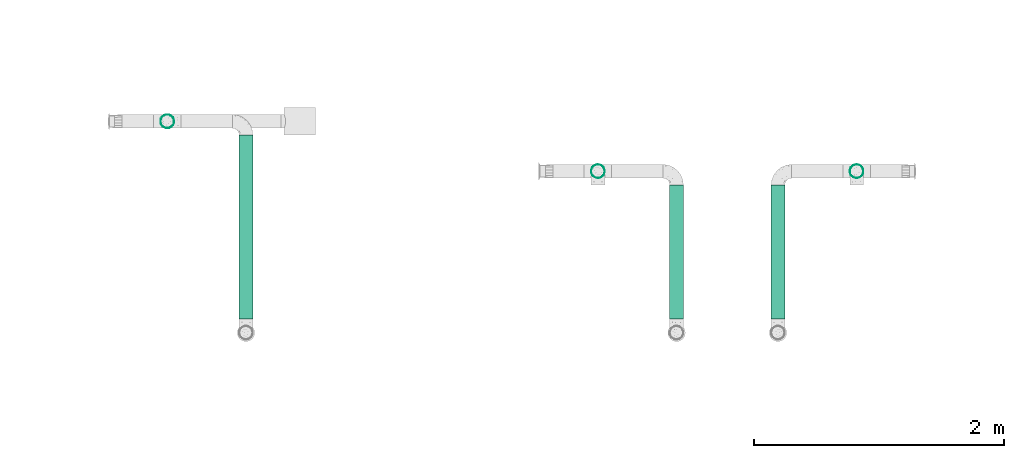
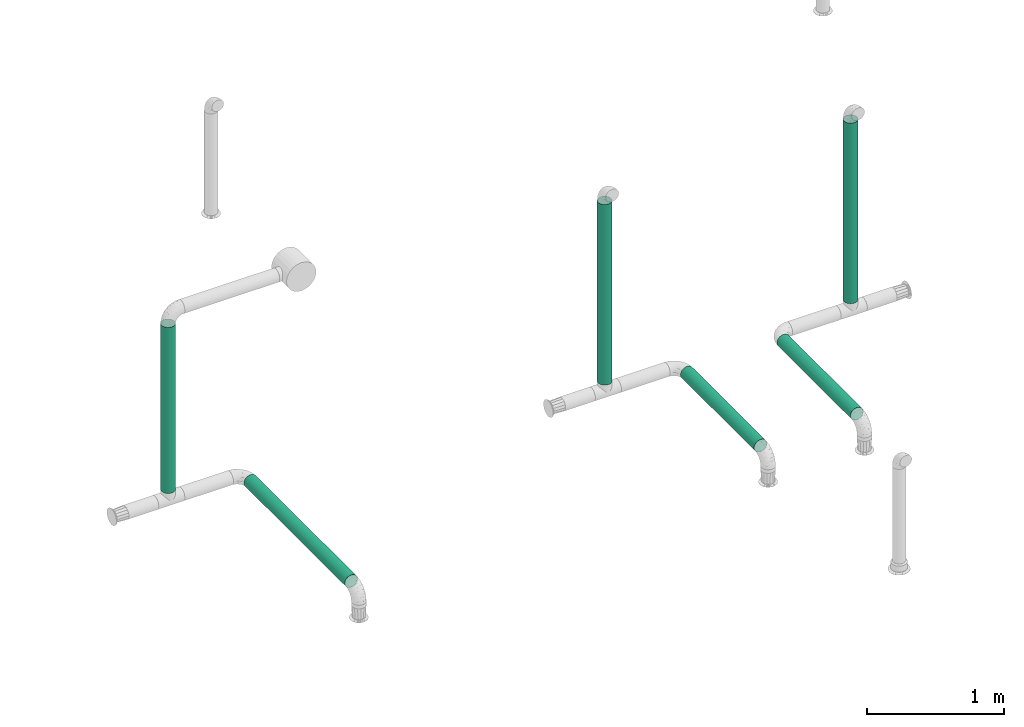
# One storey, part 2 of 103: 6 flow segments.
"""IFC2X3 building model written with IfcOpenShell, lengths in millimetres."""

import ifcopenshell
import ifcopenshell.guid

model = None  # the IFC model being written
_history = None  # IfcOwnerHistory: only IFC2X3 demands one
_inside = {}  # id of a spatial element -> (the spatial element, [elements in it])
_under = {}  # id of a project, library or spatial element -> (it, [spatial elements below it])
_declared = {}  # id of a project -> (the project, [libraries it declares])
_typed = {}  # id of a type object -> (the type object, [elements of that type])
_made_of = {}  # id of a material, layer set ... -> (it, [elements and type objects made of it])


def new_model(schema):
    """Start an empty IFC model of exactly this schema.

    Asked for "IFC4X3", IfcOpenShell would pick the latest addendum, in which some entities
    have other attributes; the version numbers below select the first issue.
    IFC2X3 requires an IfcOwnerHistory on every rooted entity: one is made here for all.
    """
    global model, _history
    if schema == "IFC4X3":
        model = ifcopenshell.file(schema_version=(4, 3, 0, 0))
    else:
        model = ifcopenshell.file(schema=schema)
    _inside.clear()
    _under.clear()
    _declared.clear()
    _typed.clear()
    _made_of.clear()
    _history = None
    if model.schema == "IFC2X3":
        org = make("IfcOrganization", Name="unknown")
        user = make(
            "IfcPersonAndOrganization",
            ThePerson=make("IfcPerson", FamilyName="unknown"),
            TheOrganization=org,
        )
        app = make(
            "IfcApplication",
            ApplicationDeveloper=org,
            Version="unknown",
            ApplicationFullName="unknown",
            ApplicationIdentifier="unknown",
        )
        _history = make(
            "IfcOwnerHistory",
            OwningUser=user,
            OwningApplication=app,
            ChangeAction="ADDED",
            CreationDate=0,
        )
    return model


def make(cls, **values):
    """One entity of the class cls with the attributes given. An attribute that is None is left unset."""
    return model.create_entity(
        cls, **{name: value for name, value in values.items() if value is not None}
    )


def entity(cls, *values):
    """Any entity or typed value of the class cls, its attributes in the order of the schema. None: left unset."""
    e = model.create_entity(cls)
    for i, value in enumerate(values):
        if value is not None:
            e[i] = value
    return e


def rooted(cls, **values):
    """An entity with a GlobalId (a new one), such as an element, a storey or a relation."""
    return make(cls, GlobalId=ifcopenshell.guid.new(), OwnerHistory=_history, **values)


def si_unit(unit_type, name, prefix=None):
    """IfcSIUnit, for example si_unit("LENGTHUNIT", "METRE", prefix="MILLI")."""
    return make("IfcSIUnit", UnitType=unit_type, Prefix=prefix, Name=name)


def converted_unit(unit_type, name, factor, base, dimensions=None, offset=None):
    """IfcConversionBasedUnit, such as the inch: factor (a typed value) times the base unit."""
    return make(
        "IfcConversionBasedUnit"
        if offset is None
        else "IfcConversionBasedUnitWithOffset",
        ConversionOffset=offset,
        Dimensions=None
        if dimensions is None
        else entity("IfcDimensionalExponents", *dimensions),
        UnitType=unit_type,
        Name=name,
        ConversionFactor=make(
            "IfcMeasureWithUnit", ValueComponent=factor, UnitComponent=base
        ),
    )


def derived_unit(unit_type, elements):
    """IfcDerivedUnit: a product of units, each with its exponent."""
    return make(
        "IfcDerivedUnit",
        Elements=[
            make("IfcDerivedUnitElement", Unit=unit, Exponent=power)
            for unit, power in elements
        ],
        UnitType=unit_type,
    )


def assignment(units):
    """IfcUnitAssignment: the units of a project."""
    return None if units is None else make("IfcUnitAssignment", Units=units)


def point(xyz):
    """IfcCartesianPoint."""
    return None if xyz is None else make("IfcCartesianPoint", Coordinates=xyz)


def direction(xyz):
    """IfcDirection."""
    return None if xyz is None else make("IfcDirection", DirectionRatios=xyz)


def frame(location, z_axis=None, x_axis=None):
    """IfcAxis2Placement3D, a coordinate frame: its origin and axes. An axis left out is left unset."""
    return make(
        "IfcAxis2Placement3D",
        Location=point(location),
        Axis=direction(z_axis),
        RefDirection=direction(x_axis),
    )


def frame_2d(location, x_axis=None):
    """IfcAxis2Placement2D, a coordinate frame in the plane: its origin and x axis."""
    return make(
        "IfcAxis2Placement2D", Location=point(location), RefDirection=direction(x_axis)
    )


def origin_with_axes():
    """The frame at (0, 0, 0) with the z axis (0, 0, 1) and the x axis (1, 0, 0) written out."""
    return frame((0.0, 0.0, 0.0), z_axis=(0.0, 0.0, 1.0), x_axis=(1.0, 0.0, 0.0))


def origin_2d_with_axis():
    """The frame at (0, 0) in the plane with the x axis (1, 0) written out."""
    return frame_2d((0.0, 0.0), x_axis=(1.0, 0.0))


def place(relative_to, where):
    """IfcLocalPlacement: puts the frame where relative to a parent placement (None: the world)."""
    return make(
        "IfcLocalPlacement", PlacementRelTo=relative_to, RelativePlacement=where
    )


def context(
    kind, dimensions, precision=None, world=None, true_north=None, identifier=None
):
    """IfcGeometricRepresentationContext, for example the 3D "Model" context."""
    return make(
        "IfcGeometricRepresentationContext",
        ContextIdentifier=identifier,
        ContextType=kind,
        CoordinateSpaceDimension=dimensions,
        Precision=precision,
        WorldCoordinateSystem=world,
        TrueNorth=true_north,
    )


def subcontext(parent, identifier, kind, view, scale=None):
    """IfcGeometricRepresentationSubContext, for example "Body" below "Model"."""
    return make(
        "IfcGeometricRepresentationSubContext",
        ContextIdentifier=identifier,
        ContextType=kind,
        ParentContext=parent,
        TargetScale=scale,
        TargetView=view,
    )


def project(units=None, contexts=None):
    """IfcProject with its units and contexts."""
    return rooted(
        "IfcProject",
        Name="project",
        RepresentationContexts=contexts,
        UnitsInContext=assignment(units),
    )


def spatial(cls, under=None, at=None, **own):
    """A site, building, storey or space (cls), placed at a placement, below another one or the project."""
    s = rooted(cls, ObjectPlacement=at, **own)
    if under is not None:
        _under.setdefault(under.id(), (under, []))[1].append(s)
    return s


def profile(cls, at=None, kind="AREA", **sizes):
    """A parametric profile (cls). Its sizes go by their IFC names, for example OverallWidth=200.0."""
    return make(cls, ProfileType=kind, Position=at, **sizes)


def hollow_circle(**sizes):
    """IfcCircleHollowProfileDef."""
    return profile("IfcCircleHollowProfileDef", **sizes)


def extrude(swept, where, along, depth):
    """IfcExtrudedAreaSolid: the profile swept, set in the frame where, extruded along a direction by depth."""
    return make(
        "IfcExtrudedAreaSolid",
        SweptArea=swept,
        Position=where,
        ExtrudedDirection=direction(along),
        Depth=depth,
    )


def shape(context_of_items, identifier, shape_type, items):
    """IfcShapeRepresentation: the items that make up one representation, for example the "Body"."""
    return make(
        "IfcShapeRepresentation",
        ContextOfItems=context_of_items,
        RepresentationIdentifier=identifier,
        RepresentationType=shape_type,
        Items=items,
    )


def source(mapping_origin, context_of_items, identifier, shape_type, items):
    """IfcRepresentationMap: a shape defined once, which mapped items show again and again."""
    return make(
        "IfcRepresentationMap",
        MappingOrigin=mapping_origin,
        MappedRepresentation=shape(context_of_items, identifier, shape_type, items),
    )


def transform(
    local_origin,
    x_axis=None,
    y_axis=None,
    z_axis=None,
    scale=None,
    scale2=None,
    scale3=None,
    uniform=True,
):
    """IfcCartesianTransformationOperator3D, or its non-uniform kind. x_axis, y_axis, z_axis: its Axis1, 2, 3."""
    if uniform:
        return make(
            "IfcCartesianTransformationOperator3D",
            Axis1=direction(x_axis),
            Axis2=direction(y_axis),
            LocalOrigin=point(local_origin),
            Scale=scale,
            Axis3=direction(z_axis),
        )
    return make(
        "IfcCartesianTransformationOperator3DnonUniform",
        Axis1=direction(x_axis),
        Axis2=direction(y_axis),
        LocalOrigin=point(local_origin),
        Scale=scale,
        Axis3=direction(z_axis),
        Scale2=scale2,
        Scale3=scale3,
    )


def mapped(mapping_source, mapping_target):
    """IfcMappedItem: shows the shape of a source again, moved by a transform."""
    return make(
        "IfcMappedItem", MappingSource=mapping_source, MappingTarget=mapping_target
    )


def material(Name=None, Category=None):
    """IfcMaterial."""
    return make("IfcMaterial", Name=Name, Category=Category)


def layer(
    of_material, thickness, ventilated=None, Name=None, Category=None, Priority=None
):
    """IfcMaterialLayer: one layer of a wall or slab, of a material (None: an air gap)."""
    return make(
        "IfcMaterialLayer",
        Material=of_material,
        LayerThickness=thickness,
        IsVentilated=ventilated,
        Name=Name,
        Category=Category,
        Priority=Priority,
    )


def layer_set(layers, Name=None):
    """IfcMaterialLayerSet."""
    return make("IfcMaterialLayerSet", MaterialLayers=layers, LayerSetName=Name)


def layer_usage(for_layer_set, set_direction, sense, offset, extent=None):
    """IfcMaterialLayerSetUsage: how a layer set lies in its element."""
    return make(
        "IfcMaterialLayerSetUsage",
        ForLayerSet=for_layer_set,
        LayerSetDirection=set_direction,
        DirectionSense=sense,
        OffsetFromReferenceLine=offset,
        ReferenceExtent=extent,
    )


def made_of(thing, what):
    """Note that an element or type object is made of a material, layer set ...; save() writes the relation."""
    if what is not None:
        _made_of.setdefault(what.id(), (what, []))[1].append(thing)
    return thing


def type_object(cls, material=None, **own):
    """A type object (cls), such as IfcWallType, which elements share."""
    return made_of(rooted(cls, **own), material)


def element(
    cls,
    number,
    at=None,
    inside=None,
    cuts=None,
    type_object=None,
    material=None,
    context=None,
    identifier="Body",
    shape_type=None,
    held_by="IfcProductDefinitionShape",
    body=None,
    shapes=None,
    **own,
):
    """One element of the class cls, such as IfcWall. Its Tag is "e" and its number.

    at: its placement. inside: the storey or other place that contains it. cuts: it is an
    opening in that element (IfcRelVoidsElement). A single representation is given by context,
    identifier, shape_type and body (its items); several are given by shapes. held_by: the class
    of the entity that holds the representations. save() writes the other relations.
    """
    e = rooted(cls, Tag="e%d" % number, ObjectPlacement=at, **own)
    if body is not None:
        shapes = [shape(context, identifier, shape_type, body)]
    if shapes is not None:
        e.Representation = make(held_by, Representations=shapes)
    if inside is not None:
        _inside.setdefault(inside.id(), (inside, []))[1].append(e)
    if cuts is not None:
        rooted(
            "IfcRelVoidsElement", RelatingBuildingElement=cuts, RelatedOpeningElement=e
        )
    if type_object is not None:
        _typed.setdefault(type_object.id(), (type_object, []))[1].append(e)
    return made_of(e, material)


def aggregate(whole, parts):
    """IfcRelAggregates: a whole, such as a stair, and the parts it consists of."""
    return rooted("IfcRelAggregates", RelatingObject=whole, RelatedObjects=parts)


def save(model, path):
    """Write the relations noted so far, then the file.

    IfcRelAggregates (storeys below a building ...), IfcRelContainedInSpatialStructure (elements
    in a storey), IfcRelDefinesByType, IfcRelAssociatesMaterial and IfcRelDeclares: one each for
    every whole, place, type object, material and project.
    """
    for whole, parts in _under.values():
        aggregate(whole, parts)
    for where, things in _inside.values():
        rooted(
            "IfcRelContainedInSpatialStructure",
            RelatedElements=things,
            RelatingStructure=where,
        )
    for kind, things in _typed.values():
        rooted("IfcRelDefinesByType", RelatedObjects=things, RelatingType=kind)
    for what, things in _made_of.values():
        rooted("IfcRelAssociatesMaterial", RelatedObjects=things, RelatingMaterial=what)
    for by, libraries in _declared.values():
        rooted("IfcRelDeclares", RelatingContext=by, RelatedDefinitions=libraries)
    model.write(path)


model = new_model("IFC2X3")

# Units and contexts
model_context = context("Model", 3, precision=1e-05, world=origin_with_axes(), true_north=direction((0.0, 1.0)))
body_context = subcontext(model_context, "Body", "Model", "MODEL_VIEW")
ifc_project = project(units=[si_unit("AREAUNIT", "SQUARE_METRE"), si_unit("VOLUMEUNIT", "CUBIC_METRE", prefix="DECI"), si_unit("TIMEUNIT", "SECOND"), si_unit("THERMODYNAMICTEMPERATUREUNIT", "DEGREE_CELSIUS"), si_unit("PRESSUREUNIT", "PASCAL"), si_unit("MASSUNIT", "GRAM", prefix="KILO"), si_unit("LENGTHUNIT", "METRE", prefix="MILLI"), si_unit("POWERUNIT", "WATT"), si_unit("ELECTRICCURRENTUNIT", "AMPERE"), si_unit("ELECTRICVOLTAGEUNIT", "VOLT"), derived_unit("VOLUMETRICFLOWRATEUNIT", [(si_unit("VOLUMEUNIT", "CUBIC_METRE", prefix="DECI"), 1), (si_unit("TIMEUNIT", "SECOND"), -1)]), derived_unit("LINEARVELOCITYUNIT", [(si_unit("LENGTHUNIT", "METRE"), 1), (si_unit("TIMEUNIT", "SECOND"), -1)]), derived_unit("MASSDENSITYUNIT", [(si_unit("MASSUNIT", "GRAM", prefix="KILO"), 1), (si_unit("VOLUMEUNIT", "CUBIC_METRE"), -1)]), converted_unit("PLANEANGLEUNIT", "DEGREE", entity("IfcRatioMeasure", 0.01745), si_unit("PLANEANGLEUNIT", "RADIAN"), dimensions=[0, 0, 0, 0, 0, 0, 0])], contexts=[model_context])

# Site, building, storey
site_placement = place(None, origin_with_axes())
site = spatial("IfcSite", under=ifc_project, at=site_placement, CompositionType="ELEMENT")
building_placement = place(site_placement, origin_with_axes())
building = spatial("IfcBuilding", under=site, at=building_placement, Name="mc-building", CompositionType="ELEMENT")
storey_placement = place(building_placement, frame((0.0, 0.0, 5900.0), z_axis=(0.0, 0.0, 1.0), x_axis=(1.0, 0.0, 0.0)))
storey = spatial("IfcBuildingStorey", under=building, at=storey_placement, Name="3. Korrus", CompositionType="ELEMENT", Elevation=5900.0)

# Flow segments
ifc_material = material(Name="FZ1")
ifc_layer = layer(ifc_material, 0.0)
ifc_layer_set = layer_set([ifc_layer], Name="FZ1")
ifc_layer_usage = layer_usage(ifc_layer_set, "AXIS1", "POSITIVE", 0.0)
duct_segment_type = type_object("IfcDuctSegmentType", PredefinedType="RIGIDSEGMENT")
shared_shape_1 = source(origin_with_axes(), body_context, "Body", "SweptSolid", [
    extrude(hollow_circle(Radius=55.0, WallThickness=2.0, at=origin_2d_with_axis()), frame((0.0, 0.0, 0.0), z_axis=(1.0, 0.0, 0.0), x_axis=(0.0, 1.0, 0.0)), (0.0, 0.0, 1.0), 1074.1),
])
for number, where, z_axis, x_axis in (
    (1, (11439.21808, 9367.62755, 2345.0), (0.0, 0.0, 1.0), (0.0, -1.0, 0.0)),
    (2, (12251.54332, 9367.62755, 2345.0), (0.0, 0.0, 1.0), (0.0, -1.0, 0.0)),
):
    element("IfcFlowSegment", number, at=place(storey_placement, frame(where, z_axis=z_axis, x_axis=x_axis)), inside=storey, type_object=duct_segment_type, material=ifc_layer_usage, context=body_context, shape_type="MappedRepresentation", body=[
        mapped(shared_shape_1, transform((0.0, 0.0, 0.0), scale=1.0)),
    ])
shared_shape_2 = source(origin_with_axes(), body_context, "Body", "SweptSolid", [
    extrude(hollow_circle(Radius=55.0, WallThickness=2.0, at=origin_2d_with_axis()), frame((0.0, 0.0, 0.0), z_axis=(1.0, 0.0, 0.0), x_axis=(0.0, 1.0, 0.0)), (0.0, 0.0, 1.0), 1474.1),
])
flow_segment_1_placement = place(storey_placement, frame((7989.21808, 9767.62755, 2345.0), z_axis=(0.0, 0.0, 1.0), x_axis=(0.0, -1.0, 0.0)))
element("IfcFlowSegment", 3, at=flow_segment_1_placement, inside=storey, type_object=duct_segment_type, material=ifc_layer_usage, context=body_context, shape_type="MappedRepresentation", body=[
    mapped(shared_shape_2, transform((0.0, 0.0, 0.0), scale=1.0)),
])
shared_shape_3 = source(origin_with_axes(), body_context, "Body", "SweptSolid", [
    extrude(hollow_circle(Radius=55.0, WallThickness=2.0, at=origin_2d_with_axis()), frame((0.0, 0.0, 0.0), z_axis=(1.0, 0.0, 0.0), x_axis=(0.0, 1.0, 0.0)), (0.0, 0.0, 1.0), 1479.3),
])
flow_segment_2_placement = place(storey_placement, frame((7359.16476, 9877.62755, 2425.0), z_axis=(1.0, 0.0, 0.0), x_axis=(0.0, 0.0, 1.0)))
element("IfcFlowSegment", 4, at=flow_segment_2_placement, inside=storey, type_object=duct_segment_type, material=ifc_layer_usage, context=body_context, shape_type="MappedRepresentation", body=[
    mapped(shared_shape_3, transform((0.0, 0.0, 0.0), scale=1.0)),
])
shared_shape_4 = source(origin_with_axes(), body_context, "Body", "SweptSolid", [
    extrude(hollow_circle(Radius=55.0, WallThickness=2.0, at=origin_2d_with_axis()), frame((0.0, 0.0, 0.0), z_axis=(1.0, 0.0, 0.0), x_axis=(0.0, 1.0, 0.0)), (0.0, 0.0, 1.0), 1609.0),
])
for number, where, z_axis, x_axis in (
    (5, (10809.16476, 9477.62755, 2425.0), (1.0, 0.0, 0.0), (0.0, 0.0, 1.0)),
    (6, (12881.59664, 9477.62755, 2425.0), (-1.0, 0.0, 0.0), (0.0, 0.0, 1.0)),
):
    element("IfcFlowSegment", number, at=place(storey_placement, frame(where, z_axis=z_axis, x_axis=x_axis)), inside=storey, type_object=duct_segment_type, material=ifc_layer_usage, context=body_context, shape_type="MappedRepresentation", body=[
        mapped(shared_shape_4, transform((0.0, 0.0, 0.0), scale=1.0)),
    ])

save(model, "model.ifc")
